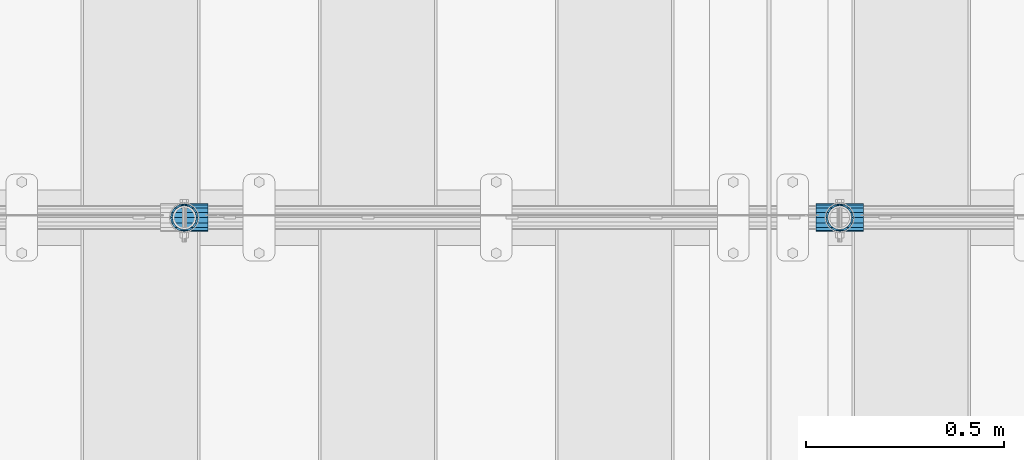
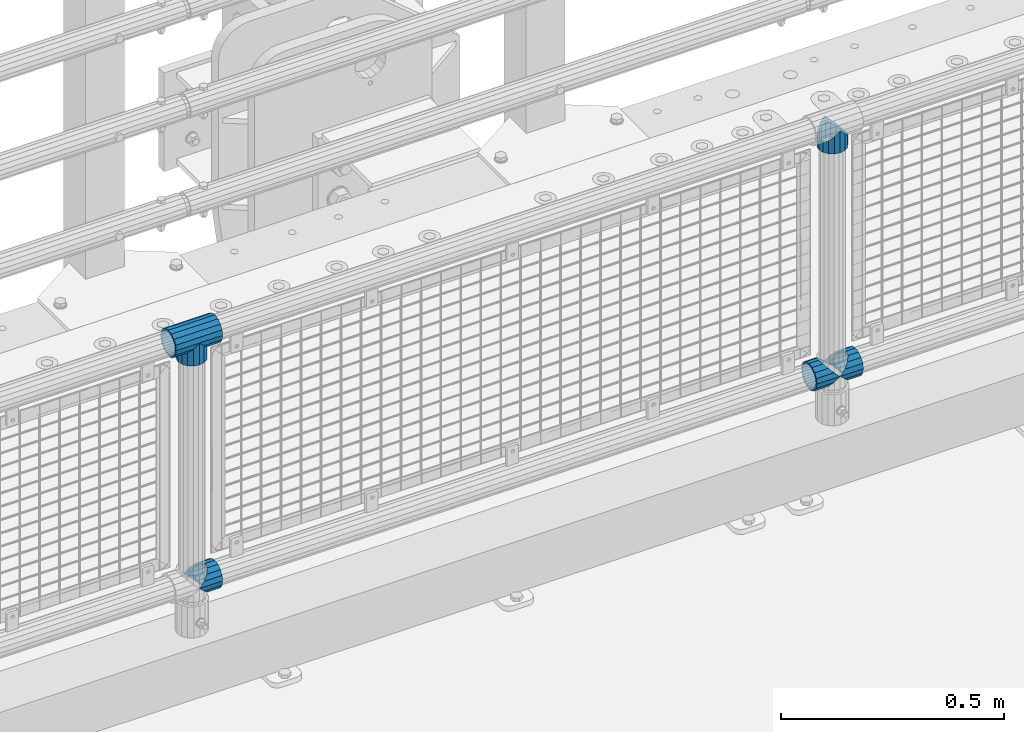
# One storey, part 122 of 193: 6 beams.
"""IFC2X3 building model written with IfcOpenShell, lengths in millimetres."""

from ifc_helpers import new_model, si_unit, frame, origin_with_axes, place, context, subcontext, project, spatial, faceted_brep, material, type_object, element, save


model = new_model("IFC2X3")

# Units and contexts
model_context = context("Model", 3, precision=1e-05, world=origin_with_axes())
body_context = subcontext(model_context, "Body", "Model", "MODEL_VIEW")
ifc_project = project(units=[si_unit("LENGTHUNIT", "METRE", prefix="MILLI"), si_unit("AREAUNIT", "SQUARE_METRE"), si_unit("VOLUMEUNIT", "CUBIC_METRE"), si_unit("MASSUNIT", "GRAM", prefix="KILO"), si_unit("TIMEUNIT", "SECOND"), si_unit("PLANEANGLEUNIT", "RADIAN"), si_unit("SOLIDANGLEUNIT", "STERADIAN"), si_unit("THERMODYNAMICTEMPERATUREUNIT", "DEGREE_CELSIUS"), si_unit("LUMINOUSINTENSITYUNIT", "LUMEN")], contexts=[model_context])

# Site, building, storey
site_placement = place(None, origin_with_axes())
site = spatial("IfcSite", under=ifc_project, at=site_placement, CompositionType="ELEMENT")
building_placement = place(site_placement, origin_with_axes())
building = spatial("IfcBuilding", under=site, at=building_placement, Name="Standard", CompositionType="ELEMENT")
storey_placement = place(building_placement, origin_with_axes())
storey = spatial("IfcBuildingStorey", under=building, at=storey_placement, Name="Undefined", CompositionType="ELEMENT", Elevation=0.0)

# Beams
ifc_material = material(Name="Misc_Undefined")
beam_type = type_object("IfcBeamType", PredefinedType="NOTDEFINED")
beam_1_placement = place(storey_placement, frame((-31941.15, 28664.5, 298.170000000001), z_axis=(0.0, 1.0, 0.0), x_axis=(1.0, 0.0, 0.0)))
element("IfcBeam", 1, at=beam_1_placement, inside=storey, type_object=beam_type, material=ifc_material, context=body_context, shape_type="Brep", body=[
    faceted_brep([(60.1500000000015, 0.0, -35.1500000000015), (46.6986773523677, 13.4513226476329, -32.4743655677703), (46.6986773523677, -13.4513226476329, -32.4743655677703), (33.0273231408864, 21.4606908090117, 21.46069080901), (27.6756344322312, 26.8123795176734, 13.4513226476338), (27.6756344322312, 32.4743655677717, 13.4513226476338), (35.2951966412948, 24.8548033587072, 24.8548033587067), (35.2951966412948, 16.3810424080078, 24.8548033587067), (27.3102561882843, 28.0397438117175, 11.614442172282), (25.0, 30.35, 0.0), (25.0, 35.15, 0.0), (27.6756344322312, 26.8123795176755, -13.4513226476338), (27.6756344322312, 32.4743655677717, -13.4513226476338), (27.3102561882843, 28.0397438117175, -11.614442172282), (35.2951966412948, 16.3810424080013, -24.8548033587067), (35.2951966412948, 24.8548033587072, -24.8548033587067), (33.0273231408974, 21.4606908090117, -21.46069080901), (40.0617968770202, 11.6144421722805, -28.0397438117179), (43.519339601633, 0.0, -30.3499999999985), (40.0617968770202, -11.6144421722805, -28.0397438117179), (35.2951966412948, -16.3810424080013, -24.8548033587067), (35.2951966412948, -24.8548033587072, -24.8548033587067), (33.0273231408974, -21.4606908090117, -21.46069080901), (27.6756344322312, -26.8123795176734, -13.4513226476338), (27.6756344322312, -32.4743655677717, -13.4513226476338), (27.3102561882843, -28.0397438117175, -11.614442172282), (25.0, -30.35, 0.0), (25.0, -35.15, 0.0), (27.3102561882843, -28.0397438117175, 11.614442172282), (27.6756344322312, -26.8123795176755, 13.4513226476338), (27.6756344322312, -32.4743655677717, 13.4513226476338), (33.0273231408864, -21.4606908090117, 21.46069080901), (35.2951966412948, -16.3810424080013, 24.8548033587067), (35.2951966412948, -24.8548033587072, 24.8548033587067), (60.1500000000015, 0.0, 35.1500000000015), (46.6986773523677, -13.4513226476329, 32.4743655677703), (46.6986773523677, 13.4513226476329, 32.4743655677703), (40.0617968770275, -11.6144421722805, 28.0397438117179), (43.5193396016439, 0.0, 30.3499999999985), (40.0617968770275, 11.6144421722805, 28.0397438117179), (0.0, -32.4743655677703, -13.4513226476338), (0.0, -24.8548033587067, -24.8548033587067), (0.0, -13.4513226476338, -32.4743655677703), (0.0, 0.0, -35.1500000000015), (0.0, 13.4513226476338, -32.4743655677703), (0.0, 24.8548033587067, -24.8548033587067), (0.0, 32.4743655677703, -13.4513226476338), (0.0, 35.1500000000015, 0.0), (0.0, 32.4743655677703, 13.4513226476338), (0.0, 24.8548033587067, 24.8548033587067), (0.0, 13.4513226476338, 32.4743655677703), (0.0, 0.0, 35.1500000000015), (0.0, -32.4743655677703, 13.4513226476338), (0.0, -35.1500000000015, 0.0), (0.0, -24.8548033587067, 24.8548033587067), (0.0, -13.4513226476338, 32.4743655677703), (0.0, -28.0397438117179, -11.614442172282), (0.0, -21.46069080901, -21.46069080901), (0.0, -11.614442172282, -28.0397438117179), (0.0, 0.0, -30.3499999999985), (0.0, 11.614442172282, -28.0397438117179), (0.0, 21.46069080901, -21.46069080901), (0.0, 28.0397438117179, -11.614442172282), (0.0, 30.3499999999985, 0.0), (0.0, 28.0397438117179, 11.614442172282), (0.0, 21.46069080901, 21.46069080901), (0.0, 11.614442172282, 28.0397438117179), (0.0, 0.0, 30.3499999999985), (0.0, -11.614442172282, 28.0397438117179), (0.0, -21.46069080901, 21.46069080901), (0.0, -28.0397438117179, 11.614442172282), (0.0, -30.3499999999985, 0.0)], [[[0, 1, 2]], [[3, 4, 5, 6, 7]], [[8, 9, 10, 5, 4]], [[11, 12, 10, 9, 13]], [[14, 15, 12, 11, 16]], [[2, 1, 15, 14, 17, 18, 19, 20, 21]], [[21, 20, 22, 23, 24]], [[24, 23, 25, 26, 27]], [[27, 26, 28, 29, 30]], [[30, 29, 31, 32, 33]], [[34, 35, 36]], [[33, 32, 37, 38, 39, 7, 6, 36, 35]], [[40, 41, 21, 24]], [[41, 42, 2, 21]], [[42, 43, 0, 2]], [[43, 44, 1, 0]], [[44, 45, 15, 1]], [[45, 46, 12, 15]], [[46, 47, 10, 12]], [[47, 48, 5, 10]], [[48, 49, 6, 5]], [[49, 50, 36, 6]], [[50, 51, 34, 36]], [[52, 53, 27, 30]], [[54, 52, 30, 33]], [[55, 54, 33, 35]], [[51, 55, 35, 34]], [[53, 40, 24, 27]], [[52, 54, 55, 51, 50, 49, 48, 47, 46, 45, 44, 43, 42, 41, 40, 53], [56, 57, 58, 59, 60, 61, 62, 63, 64, 65, 66, 67, 68, 69, 70, 71]], [[68, 67, 38, 37]], [[31, 69, 68, 37, 32]], [[28, 70, 69, 31, 29]], [[71, 70, 28, 26]], [[56, 71, 26, 25]], [[57, 56, 25, 23, 22]], [[58, 57, 22, 20, 19]], [[59, 58, 19, 18]], [[60, 59, 18, 17]], [[16, 61, 60, 17, 14]], [[13, 62, 61, 16, 11]], [[63, 62, 13, 9]], [[64, 63, 9, 8]], [[65, 64, 8, 4, 3]], [[66, 65, 3, 7, 39]], [[67, 66, 39, 38]]]),
])
beam_2_placement = place(storey_placement, frame((-31881.0, 28664.5, 298.170000000001), z_axis=(0.0, 1.0, 0.0), x_axis=(1.0, 0.0, 0.0)))
element("IfcBeam", 2, at=beam_2_placement, inside=storey, type_object=beam_type, material=ifc_material, context=body_context, shape_type="Brep", body=[
    faceted_brep([(0.0, 0.0, 35.1500000000015), (13.4513226476338, 13.4513226476329, 32.4743655677703), (13.4513226476338, -13.4513226476329, 32.4743655677703), (24.8548033587067, -16.3810424080013, -24.8548033587067), (24.8548033587067, -24.8548033587072, -24.8548033587067), (32.4743655677703, -32.4743655677717, -13.4513226476338), (32.4743655677703, -26.8123795176754, -13.4513226476338), (27.1226768591114, -21.4606908090117, -21.46069080901), (0.0, 0.0, -35.1500000000015), (13.4513226476338, -13.4513226476329, -32.4743655677703), (13.4513226476338, 13.4513226476329, -32.4743655677703), (20.0882031229849, -11.6144421722805, -28.0397438117179), (16.6306603983721, 0.0, -30.3499999999985), (20.0882031229849, 11.6144421722805, -28.0397438117179), (24.8548033587067, 16.3810424080013, -24.8548033587067), (24.8548033587067, 24.8548033587072, -24.8548033587067), (27.1226768591114, 21.4606908090117, -21.46069080901), (32.4743655677703, 26.8123795176776, -13.4513226476338), (32.4743655677703, 32.4743655677717, -13.4513226476338), (32.8397438117172, 28.0397438117175, -11.614442172282), (35.1500000000015, 30.35, 0.0), (35.1500000000015, 35.15, 0.0), (32.8397438117208, 28.0397438117175, 11.614442172282), (32.4743655677703, 26.8123795176754, 13.4513226476338), (32.4743655677703, 32.4743655677717, 13.4513226476338), (27.1226768591041, 21.4606908090117, 21.46069080901), (24.8548033587067, 16.3810424080078, 24.8548033587067), (24.8548033587067, 24.8548033587072, 24.8548033587067), (20.0882031229849, 11.6144421722805, 28.0397438117179), (16.6306603983685, 0.0, 30.3499999999985), (20.0882031229849, -11.6144421722805, 28.0397438117179), (24.8548033587067, -16.3810424080013, 24.8548033587067), (24.8548033587067, -24.8548033587072, 24.8548033587067), (27.1226768591041, -21.4606908090117, 21.46069080901), (32.4743655677703, -26.8123795176776, 13.4513226476338), (32.4743655677703, -32.4743655677717, 13.4513226476338), (32.8397438117208, -28.0397438117175, 11.614442172282), (35.1500000000015, -30.35, 0.0), (35.1500000000015, -35.15, 0.0), (32.8397438117172, -28.0397438117175, -11.614442172282), (60.1500000000015, -24.8548033587072, -24.8548033587067), (60.1500000000015, -32.4743655677717, -13.4513226476338), (60.1500000000015, -13.4513226476329, -32.4743655677703), (60.1500000000015, 0.0, -35.1500000000015), (60.1500000000015, 13.4513226476329, -32.4743655677703), (60.1500000000015, 24.8548033587072, -24.8548033587067), (60.1500000000015, 32.4743655677717, -13.4513226476338), (60.1500000000015, 35.15, 0.0), (60.1500000000015, 32.4743655677717, 13.4513226476338), (60.1500000000015, 24.8548033587072, 24.8548033587067), (60.1500000000015, 13.4513226476329, 32.4743655677703), (60.1500000000015, 0.0, 35.1500000000015), (60.1500000000015, -13.4513226476329, 32.4743655677703), (60.1500000000015, -24.8548033587072, 24.8548033587067), (60.1500000000015, -32.4743655677717, 13.4513226476338), (60.1500000000015, -35.15, 0.0), (60.1500000000015, -21.4606908090117, 21.46069080901), (60.1500000000015, -11.6144421722805, 28.0397438117179), (60.1500000000015, 0.0, 30.3499999999985), (60.1500000000015, 11.6144421722805, 28.0397438117179), (60.1500000000015, 21.4606908090117, 21.46069080901), (60.1500000000015, 28.0397438117175, 11.614442172282), (60.1500000000015, 30.35, 0.0), (60.1500000000015, 28.0397438117175, -11.614442172282), (60.1500000000015, 21.4606908090117, -21.46069080901), (60.1500000000015, 11.6144421722805, -28.0397438117179), (60.1500000000015, 0.0, -30.3499999999985), (60.1500000000015, -11.6144421722805, -28.0397438117179), (60.1500000000015, -21.4606908090117, -21.46069080901), (60.1500000000015, -28.0397438117175, -11.614442172282), (60.1500000000015, -30.35, 0.0), (60.1500000000015, -28.0397438117175, 11.614442172282)], [[[0, 1, 2]], [[3, 4, 5, 6, 7]], [[8, 9, 10]], [[10, 9, 4, 3, 11, 12, 13, 14, 15]], [[15, 14, 16, 17, 18]], [[18, 17, 19, 20, 21]], [[21, 20, 22, 23, 24]], [[24, 23, 25, 26, 27]], [[27, 26, 28, 29, 30, 31, 32, 2, 1]], [[33, 34, 35, 32, 31]], [[36, 37, 38, 35, 34]], [[6, 5, 38, 37, 39]], [[40, 41, 5, 4]], [[42, 40, 4, 9]], [[43, 42, 9, 8]], [[44, 43, 8, 10]], [[45, 44, 10, 15]], [[46, 45, 15, 18]], [[47, 46, 18, 21]], [[48, 47, 21, 24]], [[49, 48, 24, 27]], [[50, 49, 27, 1]], [[51, 50, 1, 0]], [[52, 51, 0, 2]], [[53, 52, 2, 32]], [[54, 53, 32, 35]], [[55, 54, 35, 38]], [[41, 55, 38, 5]], [[40, 42, 43, 44, 45, 46, 47, 48, 49, 50, 51, 52, 53, 54, 55, 41], [56, 57, 58, 59, 60, 61, 62, 63, 64, 65, 66, 67, 68, 69, 70, 71]], [[71, 70, 37, 36]], [[56, 71, 36, 34, 33]], [[57, 56, 33, 31, 30]], [[58, 57, 30, 29]], [[59, 58, 29, 28]], [[25, 60, 59, 28, 26]], [[22, 61, 60, 25, 23]], [[62, 61, 22, 20]], [[63, 62, 20, 19]], [[64, 63, 19, 17, 16]], [[65, 64, 16, 14, 13]], [[66, 65, 13, 12]], [[67, 66, 12, 11]], [[7, 68, 67, 11, 3]], [[39, 69, 68, 7, 6]], [[70, 69, 39, 37]]]),
])
beam_3_placement = place(storey_placement, frame((-31881.0, 28664.5, 969.85), z_axis=(0.0, 1.0, 0.0), x_axis=(0.0, 0.0, -1.0)))
element("IfcBeam", 3, at=beam_3_placement, inside=storey, type_object=beam_type, material=ifc_material, context=body_context, shape_type="Brep", body=[
    faceted_brep([(0.0, 0.0, 35.1500000000015), (13.4513226476338, 13.4513226476329, 32.4743655677703), (13.4513226476338, -13.4513226476329, 32.4743655677703), (24.8548033587067, -16.3810424080013, -24.8548033587067), (24.8548033587067, -24.8548033587072, -24.8548033587067), (32.4743655677703, -32.4743655677717, -13.4513226476338), (32.4743655677703, -26.8123795176754, -13.4513226476338), (27.1226768591114, -21.4606908090117, -21.46069080901), (0.0, 0.0, -35.1500000000015), (13.4513226476338, -13.4513226476329, -32.4743655677703), (13.4513226476338, 13.4513226476329, -32.4743655677703), (20.0882031229849, -11.6144421722805, -28.0397438117179), (16.6306603983721, 0.0, -30.3499999999985), (20.0882031229849, 11.6144421722805, -28.0397438117179), (24.8548033587067, 16.3810424080013, -24.8548033587067), (24.8548033587067, 24.8548033587072, -24.8548033587067), (27.1226768591114, 21.4606908090117, -21.46069080901), (32.4743655677703, 26.8123795176776, -13.4513226476338), (32.4743655677703, 32.4743655677717, -13.4513226476338), (32.8397438117172, 28.0397438117175, -11.614442172282), (35.1500000000015, 30.35, 0.0), (35.1500000000015, 35.15, 0.0), (32.8397438117208, 28.0397438117175, 11.614442172282), (32.4743655677703, 26.8123795176754, 13.4513226476338), (32.4743655677703, 32.4743655677717, 13.4513226476338), (27.1226768591041, 21.4606908090117, 21.46069080901), (24.8548033587067, 16.3810424080078, 24.8548033587067), (24.8548033587067, 24.8548033587072, 24.8548033587067), (20.0882031229849, 11.6144421722805, 28.0397438117179), (16.6306603983685, 0.0, 30.3499999999985), (20.0882031229849, -11.6144421722805, 28.0397438117179), (24.8548033587067, -16.3810424080013, 24.8548033587067), (24.8548033587067, -24.8548033587072, 24.8548033587067), (27.1226768591041, -21.4606908090117, 21.46069080901), (32.4743655677703, -26.8123795176776, 13.4513226476338), (32.4743655677703, -32.4743655677717, 13.4513226476338), (32.8397438117208, -28.0397438117175, 11.614442172282), (35.1500000000015, -30.35, 0.0), (35.1500000000015, -35.15, 0.0), (32.8397438117172, -28.0397438117175, -11.614442172282), (60.1500000000015, -24.8548033587072, -24.8548033587067), (60.1500000000015, -32.4743655677717, -13.4513226476338), (60.1500000000015, -13.4513226476329, -32.4743655677703), (60.1500000000015, 0.0, -35.1500000000015), (60.1500000000015, 13.4513226476329, -32.4743655677703), (60.1500000000015, 24.8548033587072, -24.8548033587067), (60.1500000000015, 32.4743655677717, -13.4513226476338), (60.1500000000015, 35.15, 0.0), (60.1500000000015, 32.4743655677717, 13.4513226476338), (60.1500000000015, 24.8548033587072, 24.8548033587067), (60.1500000000015, 13.4513226476329, 32.4743655677703), (60.1500000000015, 0.0, 35.1500000000015), (60.1500000000015, -13.4513226476329, 32.4743655677703), (60.1500000000015, -24.8548033587072, 24.8548033587067), (60.1500000000015, -32.4743655677717, 13.4513226476338), (60.1500000000015, -35.15, 0.0), (60.1500000000015, -21.4606908090117, 21.46069080901), (60.1500000000015, -11.6144421722805, 28.0397438117179), (60.1500000000015, 0.0, 30.3499999999985), (60.1500000000015, 11.6144421722805, 28.0397438117179), (60.1500000000015, 21.4606908090117, 21.46069080901), (60.1500000000015, 28.0397438117175, 11.614442172282), (60.1500000000015, 30.35, 0.0), (60.1500000000015, 28.0397438117175, -11.614442172282), (60.1500000000015, 21.4606908090117, -21.46069080901), (60.1500000000015, 11.6144421722805, -28.0397438117179), (60.1500000000015, 0.0, -30.3499999999985), (60.1500000000015, -11.6144421722805, -28.0397438117179), (60.1500000000015, -21.4606908090117, -21.46069080901), (60.1500000000015, -28.0397438117175, -11.614442172282), (60.1500000000015, -30.35, 0.0), (60.1500000000015, -28.0397438117175, 11.614442172282)], [[[0, 1, 2]], [[3, 4, 5, 6, 7]], [[8, 9, 10]], [[10, 9, 4, 3, 11, 12, 13, 14, 15]], [[15, 14, 16, 17, 18]], [[18, 17, 19, 20, 21]], [[21, 20, 22, 23, 24]], [[24, 23, 25, 26, 27]], [[27, 26, 28, 29, 30, 31, 32, 2, 1]], [[33, 34, 35, 32, 31]], [[36, 37, 38, 35, 34]], [[6, 5, 38, 37, 39]], [[40, 41, 5, 4]], [[42, 40, 4, 9]], [[43, 42, 9, 8]], [[44, 43, 8, 10]], [[45, 44, 10, 15]], [[46, 45, 15, 18]], [[47, 46, 18, 21]], [[48, 47, 21, 24]], [[49, 48, 24, 27]], [[50, 49, 27, 1]], [[51, 50, 1, 0]], [[52, 51, 0, 2]], [[53, 52, 2, 32]], [[54, 53, 32, 35]], [[55, 54, 35, 38]], [[41, 55, 38, 5]], [[40, 42, 43, 44, 45, 46, 47, 48, 49, 50, 51, 52, 53, 54, 55, 41], [56, 57, 58, 59, 60, 61, 62, 63, 64, 65, 66, 67, 68, 69, 70, 71]], [[71, 70, 37, 36]], [[56, 71, 36, 34, 33]], [[57, 56, 33, 31, 30]], [[58, 57, 30, 29]], [[59, 58, 29, 28]], [[25, 60, 59, 28, 26]], [[22, 61, 60, 25, 23]], [[62, 61, 22, 20]], [[63, 62, 20, 19]], [[64, 63, 19, 17, 16]], [[65, 64, 16, 14, 13]], [[66, 65, 13, 12]], [[67, 66, 12, 11]], [[7, 68, 67, 11, 3]], [[39, 69, 68, 7, 6]], [[70, 69, 39, 37]]]),
])
beam_4_placement = place(storey_placement, frame((-33539.0, 28664.5, 298.170000000001), z_axis=(0.0, 1.0, 0.0), x_axis=(1.0, 0.0, 0.0)))
element("IfcBeam", 4, at=beam_4_placement, inside=storey, type_object=beam_type, material=ifc_material, context=body_context, shape_type="Brep", body=[
    faceted_brep([(0.0, 0.0, 35.1500000000015), (13.4513226476338, 13.4513226476329, 32.4743655677703), (13.4513226476338, -13.4513226476329, 32.4743655677703), (24.8548033587067, -16.3810424080013, -24.8548033587067), (24.8548033587067, -24.8548033587072, -24.8548033587067), (32.4743655677703, -32.4743655677717, -13.4513226476338), (32.4743655677703, -26.8123795176754, -13.4513226476338), (27.1226768591114, -21.4606908090117, -21.46069080901), (0.0, 0.0, -35.1500000000015), (13.4513226476338, -13.4513226476329, -32.4743655677703), (13.4513226476338, 13.4513226476329, -32.4743655677703), (20.0882031229849, -11.6144421722805, -28.0397438117179), (16.6306603983721, 0.0, -30.3499999999985), (20.0882031229849, 11.6144421722805, -28.0397438117179), (24.8548033587067, 16.3810424080013, -24.8548033587067), (24.8548033587067, 24.8548033587072, -24.8548033587067), (27.1226768591114, 21.4606908090117, -21.46069080901), (32.4743655677703, 26.8123795176776, -13.4513226476338), (32.4743655677703, 32.4743655677717, -13.4513226476338), (32.8397438117172, 28.0397438117175, -11.614442172282), (35.1500000000015, 30.35, 0.0), (35.1500000000015, 35.15, 0.0), (32.8397438117208, 28.0397438117175, 11.614442172282), (32.4743655677703, 26.8123795176754, 13.4513226476338), (32.4743655677703, 32.4743655677717, 13.4513226476338), (27.1226768591041, 21.4606908090117, 21.46069080901), (24.8548033587067, 16.3810424080078, 24.8548033587067), (24.8548033587067, 24.8548033587072, 24.8548033587067), (20.0882031229849, 11.6144421722805, 28.0397438117179), (16.6306603983685, 0.0, 30.3499999999985), (20.0882031229849, -11.6144421722805, 28.0397438117179), (24.8548033587067, -16.3810424080013, 24.8548033587067), (24.8548033587067, -24.8548033587072, 24.8548033587067), (27.1226768591041, -21.4606908090117, 21.46069080901), (32.4743655677703, -26.8123795176776, 13.4513226476338), (32.4743655677703, -32.4743655677717, 13.4513226476338), (32.8397438117208, -28.0397438117175, 11.614442172282), (35.1500000000015, -30.35, 0.0), (35.1500000000015, -35.15, 0.0), (32.8397438117172, -28.0397438117175, -11.614442172282), (60.1500000000015, -24.8548033587072, -24.8548033587067), (60.1500000000015, -32.4743655677717, -13.4513226476338), (60.1500000000015, -13.4513226476329, -32.4743655677703), (60.1500000000015, 0.0, -35.1500000000015), (60.1500000000015, 13.4513226476329, -32.4743655677703), (60.1500000000015, 24.8548033587072, -24.8548033587067), (60.1500000000015, 32.4743655677717, -13.4513226476338), (60.1500000000015, 35.15, 0.0), (60.1500000000015, 32.4743655677717, 13.4513226476338), (60.1500000000015, 24.8548033587072, 24.8548033587067), (60.1500000000015, 13.4513226476329, 32.4743655677703), (60.1500000000015, 0.0, 35.1500000000015), (60.1500000000015, -13.4513226476329, 32.4743655677703), (60.1500000000015, -24.8548033587072, 24.8548033587067), (60.1500000000015, -32.4743655677717, 13.4513226476338), (60.1500000000015, -35.15, 0.0), (60.1500000000015, -21.4606908090117, 21.46069080901), (60.1500000000015, -11.6144421722805, 28.0397438117179), (60.1500000000015, 0.0, 30.3499999999985), (60.1500000000015, 11.6144421722805, 28.0397438117179), (60.1500000000015, 21.4606908090117, 21.46069080901), (60.1500000000015, 28.0397438117175, 11.614442172282), (60.1500000000015, 30.35, 0.0), (60.1500000000015, 28.0397438117175, -11.614442172282), (60.1500000000015, 21.4606908090117, -21.46069080901), (60.1500000000015, 11.6144421722805, -28.0397438117179), (60.1500000000015, 0.0, -30.3499999999985), (60.1500000000015, -11.6144421722805, -28.0397438117179), (60.1500000000015, -21.4606908090117, -21.46069080901), (60.1500000000015, -28.0397438117175, -11.614442172282), (60.1500000000015, -30.35, 0.0), (60.1500000000015, -28.0397438117175, 11.614442172282)], [[[0, 1, 2]], [[3, 4, 5, 6, 7]], [[8, 9, 10]], [[10, 9, 4, 3, 11, 12, 13, 14, 15]], [[15, 14, 16, 17, 18]], [[18, 17, 19, 20, 21]], [[21, 20, 22, 23, 24]], [[24, 23, 25, 26, 27]], [[27, 26, 28, 29, 30, 31, 32, 2, 1]], [[33, 34, 35, 32, 31]], [[36, 37, 38, 35, 34]], [[6, 5, 38, 37, 39]], [[40, 41, 5, 4]], [[42, 40, 4, 9]], [[43, 42, 9, 8]], [[44, 43, 8, 10]], [[45, 44, 10, 15]], [[46, 45, 15, 18]], [[47, 46, 18, 21]], [[48, 47, 21, 24]], [[49, 48, 24, 27]], [[50, 49, 27, 1]], [[51, 50, 1, 0]], [[52, 51, 0, 2]], [[53, 52, 2, 32]], [[54, 53, 32, 35]], [[55, 54, 35, 38]], [[41, 55, 38, 5]], [[40, 42, 43, 44, 45, 46, 47, 48, 49, 50, 51, 52, 53, 54, 55, 41], [56, 57, 58, 59, 60, 61, 62, 63, 64, 65, 66, 67, 68, 69, 70, 71]], [[71, 70, 37, 36]], [[56, 71, 36, 34, 33]], [[57, 56, 33, 31, 30]], [[58, 57, 30, 29]], [[59, 58, 29, 28]], [[25, 60, 59, 28, 26]], [[22, 61, 60, 25, 23]], [[62, 61, 22, 20]], [[63, 62, 20, 19]], [[64, 63, 19, 17, 16]], [[65, 64, 16, 14, 13]], [[66, 65, 13, 12]], [[67, 66, 12, 11]], [[7, 68, 67, 11, 3]], [[39, 69, 68, 7, 6]], [[70, 69, 39, 37]]]),
])
beam_5_placement = place(storey_placement, frame((-33539.0, 28664.5, 969.85), z_axis=(0.0, 1.0, 0.0), x_axis=(0.0, 0.0, -1.0)))
element("IfcBeam", 5, at=beam_5_placement, inside=storey, type_object=beam_type, material=ifc_material, context=body_context, shape_type="Brep", body=[
    faceted_brep([(0.0, 0.0, 35.1500000000015), (13.4513226476338, 13.4513226476329, 32.4743655677703), (13.4513226476338, -13.4513226476329, 32.4743655677703), (24.8548033587067, -16.3810424080013, -24.8548033587067), (24.8548033587067, -24.8548033587072, -24.8548033587067), (32.4743655677703, -32.4743655677717, -13.4513226476338), (32.4743655677703, -26.8123795176754, -13.4513226476338), (27.1226768591114, -21.4606908090117, -21.46069080901), (0.0, 0.0, -35.1500000000015), (13.4513226476338, -13.4513226476329, -32.4743655677703), (13.4513226476338, 13.4513226476329, -32.4743655677703), (20.0882031229849, -11.6144421722805, -28.0397438117179), (16.6306603983721, 0.0, -30.3499999999985), (20.0882031229849, 11.6144421722805, -28.0397438117179), (24.8548033587067, 16.3810424080013, -24.8548033587067), (24.8548033587067, 24.8548033587072, -24.8548033587067), (27.1226768591114, 21.4606908090117, -21.46069080901), (32.4743655677703, 26.8123795176776, -13.4513226476338), (32.4743655677703, 32.4743655677717, -13.4513226476338), (32.8397438117172, 28.0397438117175, -11.614442172282), (35.1500000000015, 30.35, 0.0), (35.1500000000015, 35.15, 0.0), (32.8397438117208, 28.0397438117175, 11.614442172282), (32.4743655677703, 26.8123795176754, 13.4513226476338), (32.4743655677703, 32.4743655677717, 13.4513226476338), (27.1226768591041, 21.4606908090117, 21.46069080901), (24.8548033587067, 16.3810424080078, 24.8548033587067), (24.8548033587067, 24.8548033587072, 24.8548033587067), (20.0882031229849, 11.6144421722805, 28.0397438117179), (16.6306603983685, 0.0, 30.3499999999985), (20.0882031229849, -11.6144421722805, 28.0397438117179), (24.8548033587067, -16.3810424080013, 24.8548033587067), (24.8548033587067, -24.8548033587072, 24.8548033587067), (27.1226768591041, -21.4606908090117, 21.46069080901), (32.4743655677703, -26.8123795176776, 13.4513226476338), (32.4743655677703, -32.4743655677717, 13.4513226476338), (32.8397438117208, -28.0397438117175, 11.614442172282), (35.1500000000015, -30.35, 0.0), (35.1500000000015, -35.15, 0.0), (32.8397438117172, -28.0397438117175, -11.614442172282), (60.1500000000015, -24.8548033587072, -24.8548033587067), (60.1500000000015, -32.4743655677717, -13.4513226476338), (60.1500000000015, -13.4513226476329, -32.4743655677703), (60.1500000000015, 0.0, -35.1500000000015), (60.1500000000015, 13.4513226476329, -32.4743655677703), (60.1500000000015, 24.8548033587072, -24.8548033587067), (60.1500000000015, 32.4743655677717, -13.4513226476338), (60.1500000000015, 35.15, 0.0), (60.1500000000015, 32.4743655677717, 13.4513226476338), (60.1500000000015, 24.8548033587072, 24.8548033587067), (60.1500000000015, 13.4513226476329, 32.4743655677703), (60.1500000000015, 0.0, 35.1500000000015), (60.1500000000015, -13.4513226476329, 32.4743655677703), (60.1500000000015, -24.8548033587072, 24.8548033587067), (60.1500000000015, -32.4743655677717, 13.4513226476338), (60.1500000000015, -35.15, 0.0), (60.1500000000015, -21.4606908090117, 21.46069080901), (60.1500000000015, -11.6144421722805, 28.0397438117179), (60.1500000000015, 0.0, 30.3499999999985), (60.1500000000015, 11.6144421722805, 28.0397438117179), (60.1500000000015, 21.4606908090117, 21.46069080901), (60.1500000000015, 28.0397438117175, 11.614442172282), (60.1500000000015, 30.35, 0.0), (60.1500000000015, 28.0397438117175, -11.614442172282), (60.1500000000015, 21.4606908090117, -21.46069080901), (60.1500000000015, 11.6144421722805, -28.0397438117179), (60.1500000000015, 0.0, -30.3499999999985), (60.1500000000015, -11.6144421722805, -28.0397438117179), (60.1500000000015, -21.4606908090117, -21.46069080901), (60.1500000000015, -28.0397438117175, -11.614442172282), (60.1500000000015, -30.35, 0.0), (60.1500000000015, -28.0397438117175, 11.614442172282)], [[[0, 1, 2]], [[3, 4, 5, 6, 7]], [[8, 9, 10]], [[10, 9, 4, 3, 11, 12, 13, 14, 15]], [[15, 14, 16, 17, 18]], [[18, 17, 19, 20, 21]], [[21, 20, 22, 23, 24]], [[24, 23, 25, 26, 27]], [[27, 26, 28, 29, 30, 31, 32, 2, 1]], [[33, 34, 35, 32, 31]], [[36, 37, 38, 35, 34]], [[6, 5, 38, 37, 39]], [[40, 41, 5, 4]], [[42, 40, 4, 9]], [[43, 42, 9, 8]], [[44, 43, 8, 10]], [[45, 44, 10, 15]], [[46, 45, 15, 18]], [[47, 46, 18, 21]], [[48, 47, 21, 24]], [[49, 48, 24, 27]], [[50, 49, 27, 1]], [[51, 50, 1, 0]], [[52, 51, 0, 2]], [[53, 52, 2, 32]], [[54, 53, 32, 35]], [[55, 54, 35, 38]], [[41, 55, 38, 5]], [[40, 42, 43, 44, 45, 46, 47, 48, 49, 50, 51, 52, 53, 54, 55, 41], [56, 57, 58, 59, 60, 61, 62, 63, 64, 65, 66, 67, 68, 69, 70, 71]], [[71, 70, 37, 36]], [[56, 71, 36, 34, 33]], [[57, 56, 33, 31, 30]], [[58, 57, 30, 29]], [[59, 58, 29, 28]], [[25, 60, 59, 28, 26]], [[22, 61, 60, 25, 23]], [[62, 61, 22, 20]], [[63, 62, 20, 19]], [[64, 63, 19, 17, 16]], [[65, 64, 16, 14, 13]], [[66, 65, 13, 12]], [[67, 66, 12, 11]], [[7, 68, 67, 11, 3]], [[39, 69, 68, 7, 6]], [[70, 69, 39, 37]]]),
])
beam_6_placement = place(storey_placement, frame((-33599.15, 28664.5, 969.849999999999), z_axis=(0.0, 0.0, 1.0), x_axis=(1.0, 0.0, 0.0)))
element("IfcBeam", 6, at=beam_6_placement, inside=storey, type_object=beam_type, material=ifc_material, context=body_context, shape_type="Brep", body=[
    faceted_brep([(88.1897438117194, -11.614442172282, -28.0397438117176), (88.1897438117194, -11.614442172282, -32.8397438117171), (86.9623795176703, -13.4513226476338, -32.4743655677718), (81.6106908090114, -21.46069080901, -27.1226768591079), (81.6106908090114, -21.46069080901, -21.4606908090117), (76.531042407998, -24.8548033587067, -24.8548033587072), (71.7644421722835, -28.0397438117179, -20.0882031229796), (71.7644421722835, -28.0397438117179, -11.6144421722805), (60.1500000000015, -30.3499999999985, -16.6306603983672), (60.1500000000015, -30.35, 0.0), (48.5355578277195, -28.0397438117179, -20.0882031229796), (48.5355578277195, -28.0397438117179, -11.6144421722805), (43.7689575919976, -24.8548033587067, -24.8548033587072), (38.6893091909915, -21.46069080901, -27.1226768591079), (38.6893091909915, -21.46069080901, -21.4606908090117), (33.3376204823326, -13.4513226476338, -32.4743655677718), (32.1102561882835, -11.614442172282, -32.8397438117171), (32.1102561882835, -11.614442172282, -28.0397438117176), (29.8000000000029, 0.0, -35.15), (29.8000000000029, 0.0, -30.35), (32.1102561882835, 11.614442172282, -32.8397438117171), (32.1102561882835, 11.614442172282, -28.0397438117176), (33.3376204823217, 13.4513226476338, -32.4743655677718), (38.6893091909915, 21.46069080901, -27.1226768591082), (38.6893091909915, 21.46069080901, -21.4606908090117), (43.7689575920012, 24.8548033587067, -24.8548033587072), (48.5355578277195, 28.0397438117179, -20.0882031229862), (48.5355578277195, 28.0397438117179, -11.6144421722805), (60.1500000000015, 30.3499999999985, -16.6306603983672), (60.1500000000015, 30.35, 0.0), (71.7644421722835, 28.0397438117179, -20.0882031229862), (71.7644421722835, 28.0397438117179, -11.6144421722805), (76.5310424080017, 24.8548033587067, -24.8548033587072), (81.6106908090114, 21.46069080901, -27.1226768591082), (81.6106908090114, 21.46069080901, -21.4606908090117), (86.962379517674, 13.4513226476338, -32.4743655677718), (88.1897438117194, 11.614442172282, -32.8397438117171), (88.1897438117194, 11.614442172282, -28.0397438117176), (90.5, 0.0, -35.15), (90.5, 0.0, -30.35), (0.0, -21.46069080901, -21.46069080901), (0.0, -28.0397438117179, -11.614442172282), (0.0, -11.614442172282, -28.0397438117179), (0.0, 0.0, -30.3499999999985), (0.0, 11.614442172282, -28.0397438117179), (0.0, 21.46069080901, -21.46069080901), (0.0, 28.0397438117179, -11.614442172282), (0.0, 30.3499999999985, 0.0), (0.0, 32.4743655677703, -13.4513226476338), (0.0, 35.1500000000015, 0.0), (120.299999999999, 35.1500000000015, 0.0), (120.299999999999, 32.4743655677703, -13.4513226476329), (0.0, 32.4743655677703, 13.4513226476338), (120.299999999999, 32.4743655677703, 13.4513226476329), (0.0, 24.8548033587067, 24.8548033587067), (120.299999999999, 24.8548033587067, 24.8548033587072), (0.0, 13.4513226476338, 32.4743655677703), (120.299999999999, 13.4513226476338, 32.4743655677718), (0.0, 0.0, 35.1500000000015), (120.299999999999, 0.0, 35.15), (0.0, -13.4513226476338, 32.4743655677703), (120.299999999999, -13.4513226476338, 32.4743655677718), (0.0, -24.8548033587067, 24.8548033587067), (120.299999999999, -24.8548033587067, 24.8548033587072), (0.0, -32.4743655677703, 13.4513226476338), (120.299999999999, -32.4743655677703, 13.4513226476329), (0.0, -35.1500000000015, 0.0), (120.299999999999, -35.1500000000015, 0.0), (0.0, -32.4743655677703, -13.4513226476338), (120.299999999999, -32.4743655677703, -13.4513226476329), (0.0, 24.8548033587067, -24.8548033587067), (0.0, 13.4513226476338, -32.4743655677703), (0.0, 0.0, -35.1500000000015), (0.0, -13.4513226476338, -32.4743655677703), (0.0, -24.8548033587067, -24.8548033587067), (0.0, 28.0397438117179, 11.614442172282), (0.0, 21.46069080901, 21.46069080901), (0.0, 11.614442172282, 28.0397438117179), (0.0, 0.0, 30.3499999999985), (0.0, -11.614442172282, 28.0397438117179), (0.0, -21.46069080901, 21.46069080901), (0.0, -28.0397438117179, 11.614442172282), (0.0, -30.3499999999985, 0.0), (120.299999999999, -30.3499999999985, 0.0), (120.299999999999, -28.0397438117179, -11.6144421722805), (120.299999999999, -21.46069080901, -21.4606908090117), (120.299999999999, -11.614442172282, -28.0397438117176), (120.299999999999, 0.0, -30.35), (120.299999999999, 21.46069080901, -21.4606908090117), (120.299999999999, 28.0397438117179, -11.6144421722805), (120.299999999999, 11.614442172282, -28.0397438117176), (120.299999999999, 30.3499999999985, 0.0), (120.299999999999, 28.0397438117179, 11.6144421722805), (120.299999999999, 21.46069080901, 21.4606908090117), (120.299999999999, 11.614442172282, 28.0397438117176), (120.299999999999, 0.0, 30.35), (120.299999999999, -11.614442172282, 28.0397438117176), (120.299999999999, -21.46069080901, 21.4606908090117), (120.299999999999, -28.0397438117179, 11.6144421722805), (120.299999999999, -24.8548033587067, -24.8548033587072), (120.299999999999, -13.4513226476338, -32.4743655677718), (120.299999999999, 0.0, -35.15), (120.299999999999, 13.4513226476338, -32.4743655677718), (120.299999999999, 24.8548033587067, -24.8548033587072)], [[[0, 1, 2, 3, 4]], [[4, 3, 5, 6, 7]], [[7, 6, 8, 9]], [[9, 8, 10, 11]], [[11, 10, 12, 13, 14]], [[14, 13, 15, 16, 17]], [[17, 16, 18, 19]], [[19, 18, 20, 21]], [[21, 20, 22, 23, 24]], [[24, 23, 25, 26, 27]], [[27, 26, 28, 29]], [[29, 28, 30, 31]], [[31, 30, 32, 33, 34]], [[34, 33, 35, 36, 37]], [[37, 36, 38, 39]], [[39, 38, 1, 0]], [[40, 41, 11, 14]], [[42, 40, 14, 17]], [[43, 42, 17, 19]], [[44, 43, 19, 21]], [[45, 44, 21, 24]], [[46, 45, 24, 27]], [[47, 46, 27, 29]], [[48, 49, 50, 51]], [[49, 52, 53, 50]], [[52, 54, 55, 53]], [[54, 56, 57, 55]], [[56, 58, 59, 57]], [[58, 60, 61, 59]], [[60, 62, 63, 61]], [[62, 64, 65, 63]], [[64, 66, 67, 65]], [[66, 68, 69, 67]], [[64, 62, 60, 58, 56, 54, 52, 49, 48, 70, 71, 72, 73, 74, 68, 66], [41, 40, 42, 43, 44, 45, 46, 47, 75, 76, 77, 78, 79, 80, 81, 82]], [[41, 82, 9, 11]], [[83, 84, 7, 9]], [[84, 85, 4, 7]], [[85, 86, 0, 4]], [[86, 87, 39, 0]], [[88, 89, 31, 34]], [[90, 88, 34, 37]], [[87, 90, 37, 39]], [[89, 91, 29, 31]], [[75, 47, 29, 91, 92]], [[76, 75, 92, 93]], [[77, 76, 93, 94]], [[78, 77, 94, 95]], [[79, 78, 95, 96]], [[80, 79, 96, 97]], [[81, 80, 97, 98]], [[9, 82, 81, 98, 83]], [[99, 100, 101, 102, 103, 51, 50, 53, 55, 57, 59, 61, 63, 65, 67, 69], [97, 96, 95, 94, 93, 92, 91, 89, 88, 90, 87, 86, 85, 84, 83, 98]], [[35, 102, 101, 38, 36]], [[32, 103, 102, 35, 33]], [[28, 26, 25, 70, 48, 51, 103, 32, 30]], [[22, 71, 70, 25, 23]], [[18, 72, 71, 22, 20]], [[73, 72, 18, 16, 15]], [[74, 73, 15, 13, 12]], [[99, 69, 68, 74, 12, 10, 8, 6, 5]], [[100, 99, 5, 3, 2]], [[101, 100, 2, 1, 38]]]),
])

save(model, "model.ifc")
